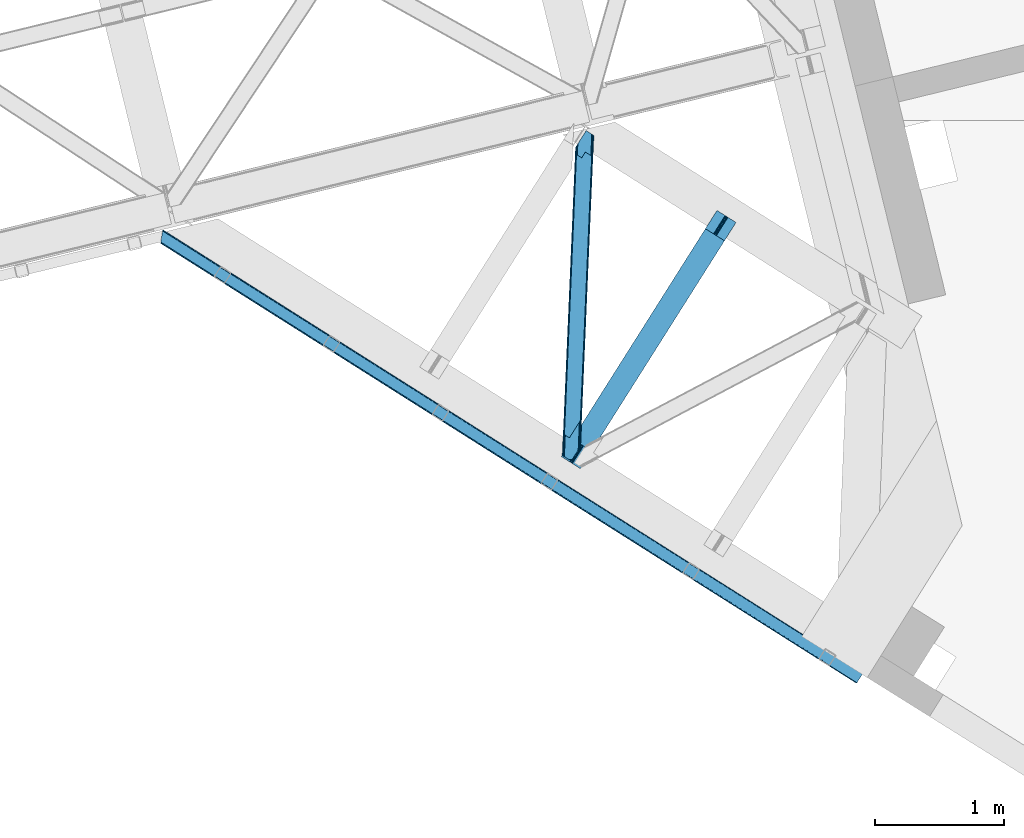
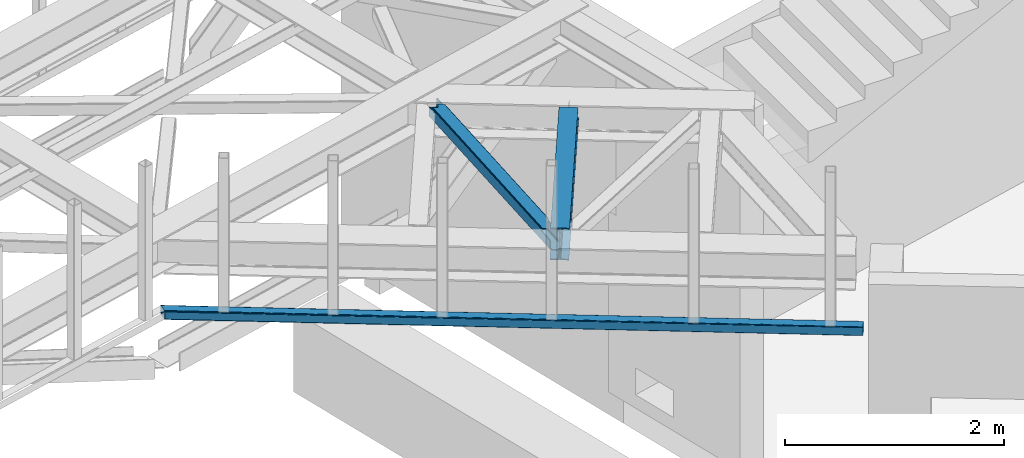
# One storey, part 49 of 67: 2 beams, 1 member.
"""IFC4 building model written with IfcOpenShell, lengths in millimetres."""

from ifc_helpers import new_model, entity, si_unit, converted_unit, derived_unit, direction, frame, origin, place, context, subcontext, project, spatial, triangles, polygons, material, type_object, element, save


model = new_model("IFC4")

# Units and contexts
model_context = context("Model", 3, precision=0.01, world=origin(), true_north=direction((6.12303176911189e-17, 1.0)))
plan_context = context("Plan", 3, precision=0.01, world=origin(), true_north=direction((6.12303176911189e-17, 1.0)))
body_context = subcontext(model_context, "Body", "Model", "MODEL_VIEW")
ifc_project = project(units=[si_unit("LENGTHUNIT", "METRE", prefix="MILLI"), si_unit("AREAUNIT", "SQUARE_METRE"), si_unit("VOLUMEUNIT", "CUBIC_METRE"), converted_unit("PLANEANGLEUNIT", "DEGREE", entity("IfcRatioMeasure", 0.0174532925199433), si_unit("PLANEANGLEUNIT", "RADIAN"), dimensions=[0, 0, 0, 0, 0, 0, 0]), si_unit("MASSUNIT", "GRAM", prefix="KILO"), derived_unit("MASSDENSITYUNIT", [(si_unit("MASSUNIT", "GRAM", prefix="KILO"), 1), (si_unit("LENGTHUNIT", "METRE"), -3)]), derived_unit("MOMENTOFINERTIAUNIT", [(si_unit("LENGTHUNIT", "METRE"), 4)]), si_unit("TIMEUNIT", "SECOND"), si_unit("FREQUENCYUNIT", "HERTZ"), si_unit("THERMODYNAMICTEMPERATUREUNIT", "DEGREE_CELSIUS"), derived_unit("THERMALTRANSMITTANCEUNIT", [(si_unit("MASSUNIT", "GRAM", prefix="KILO"), 1), (si_unit("THERMODYNAMICTEMPERATUREUNIT", "KELVIN"), -1), (si_unit("TIMEUNIT", "SECOND"), -3)]), derived_unit("VOLUMETRICFLOWRATEUNIT", [(si_unit("LENGTHUNIT", "METRE"), 3), (si_unit("TIMEUNIT", "SECOND"), -1)]), derived_unit("MASSFLOWRATEUNIT", [(si_unit("MASSUNIT", "GRAM", prefix="KILO"), 1), (si_unit("TIMEUNIT", "SECOND"), -1)]), derived_unit("ROTATIONALFREQUENCYUNIT", [(si_unit("TIMEUNIT", "SECOND"), -1)]), si_unit("ELECTRICCURRENTUNIT", "AMPERE"), si_unit("ELECTRICVOLTAGEUNIT", "VOLT"), si_unit("POWERUNIT", "WATT"), si_unit("FORCEUNIT", "NEWTON", prefix="KILO"), si_unit("ILLUMINANCEUNIT", "LUX"), si_unit("LUMINOUSFLUXUNIT", "LUMEN"), si_unit("LUMINOUSINTENSITYUNIT", "CANDELA"), derived_unit("USERDEFINED", [(si_unit("MASSUNIT", "GRAM", prefix="KILO"), -1), (si_unit("LENGTHUNIT", "METRE"), -2), (si_unit("TIMEUNIT", "SECOND"), 3), (si_unit("LUMINOUSFLUXUNIT", "LUMEN"), 1)]), derived_unit("LINEARVELOCITYUNIT", [(si_unit("LENGTHUNIT", "METRE"), 1), (si_unit("TIMEUNIT", "SECOND"), -1)]), si_unit("PRESSUREUNIT", "PASCAL"), derived_unit("USERDEFINED", [(si_unit("LENGTHUNIT", "METRE"), -2), (si_unit("MASSUNIT", "GRAM", prefix="KILO"), 1), (si_unit("TIMEUNIT", "SECOND"), -2)]), derived_unit("LINEARFORCEUNIT", [(si_unit("MASSUNIT", "GRAM", prefix="KILO"), 1), (si_unit("LENGTHUNIT", "METRE"), 1), (si_unit("TIMEUNIT", "SECOND"), -2), (si_unit("LENGTHUNIT", "METRE"), -1)]), derived_unit("PLANARFORCEUNIT", [(si_unit("MASSUNIT", "GRAM", prefix="KILO"), 1), (si_unit("LENGTHUNIT", "METRE"), 1), (si_unit("TIMEUNIT", "SECOND"), -2), (si_unit("LENGTHUNIT", "METRE"), -2)])], contexts=[model_context, plan_context])

# Site, building, storey
site_placement = place(None, origin())
site = spatial("IfcSite", under=ifc_project, at=site_placement, CompositionType="ELEMENT")
building_placement = place(site_placement, origin())
building = spatial("IfcBuilding", under=site, at=building_placement, CompositionType="ELEMENT")
storey_placement = place(building_placement, frame((0.0, 0.0, 19800.0)))
storey = spatial("IfcBuildingStorey", under=building, at=storey_placement, CompositionType="ELEMENT", Elevation=19800.0)

# Beam
ifc_material = material(Name="Metal painted (White)")
beam_type_1 = type_object("IfcBeamType", PredefinedType="BEAM")
beam_1_placement = place(storey_placement, frame((-2373.14584361384, 14260.2889328785, 3864.0)))
element("IfcBeam", 1, at=beam_1_placement, inside=storey, type_object=beam_type_1, material=ifc_material, ObjectType="Steel Beam", PredefinedType="BEAM", context=body_context, shape_type="Tessellation", body=[
    polygons([(147.919660694801, 2.16573425859679e-12, 11.0000000000018), (147.919660694804, 4.33146851719357e-12, 0.0), (1355.44607863557, 1910.06544717356, 0.0), (1355.44607863557, 1910.06544717355, 11.0000000000018), (90.4423068248274, 36.3366728266057, 11.0000000000018), (1297.96872476558, 1946.40212000016, 11.0000000000018), (85.2668642219479, 39.6085416920184, 12.2179274798152), (1292.7932821627, 1949.67398886557, 12.2179274798152), (80.8793358398553, 42.3822981822298, 15.6862915010257), (1288.40575378062, 1952.44774535578, 15.6862915010213), (77.9476831016699, 44.2356630157985, 20.8770650821548), (1285.47410104242, 1954.30111018934, 20.8770650821548), (76.9182235613008, 44.8864781975669, 26.9999999999939), (1284.44464150205, 1954.95192537111, 26.9999999999939), (1278.52785507426, 1958.69246522089, 26.9999999999939), (1278.52785507432, 1958.69246522022, 203.000000000006), (1284.44464150196, 1954.95192537085, 203.000000000006), (1207.52641794078, 2003.57894341848, 0.0), (1207.52641794077, 2003.57894341847, 10.9999999999975), (1265.00377181074, 1967.24227059188, 11.0000000000018), (1270.17921441362, 1963.97040172646, 12.2179274798152), (1274.56674279571, 1961.19664523624, 15.6862915010127), (1277.49839553388, 1959.34328040268, 20.8770650821592), (76.9182235613823, 44.8864781975192, 203.000000000006), (71.0014371335516, 48.6270180473361, 203.000000000006), (71.0014371335056, 48.6270180473665, 26.9999999999939), (69.9719775931373, 49.2778332291413, 20.8770650821592), (67.0403248549565, 51.1311980626949, 15.6862915010127), (62.6527964728685, 53.9049545529128, 12.2179274798152), (57.4773538699869, 57.176823418332, 11.0000000000018), (8.12150346973795e-12, 93.5134962449225, 10.9999999999975), (5.41433564649196e-12, 93.5134962449269, 0.0), (162.887980343835, 180.873386503032, 203.069792575793), (1195.07248712349, 1813.58297531797, 203.006342981529), (1194.53809439775, 1812.73773730252, 216.999999999998), (163.217821525431, 181.395193639939, 216.999999999998), (163.217821525544, 181.395193639874, 204.00000000001), (156.766642341062, 184.290495421957, 203.006342980143), (157.301035097542, 185.135733489758, 216.999999999998), (1188.62130797009, 1816.4782771522, 216.999999999998), (1188.6213079702, 1816.47827715213, 204.000000000006), (1188.95114918025, 1817.00008434255, 203.069791966819), (157.301035097816, 185.135733489578, 204.00000000001), (164.247281065643, 180.744378458268, 223.122934917842), (167.178933803824, 178.891013624725, 228.313708498975), (171.566462185928, 176.117257134518, 231.782072520173), (176.741904788822, 172.845388269138, 232.999999999995), (234.219258658959, 136.508715442803, 232.999999999999), (234.219258658962, 136.508715442803, 243.999999999997), (86.2995979637529, 230.022211687052, 244.000000000001), (86.2995979637521, 230.022211687052, 232.999999999999), (143.776951833897, 193.685538860712, 232.999999999999), (148.952394436778, 190.413669995315, 231.782072520181), (153.339922818875, 187.639913505108, 228.313708498984), (156.271575557062, 185.786548671563, 223.122934917842), (1187.59184842946, 1817.12909233409, 223.122934917842), (1184.66019569129, 1818.98245716763, 228.313708498979), (1180.27266730917, 1821.75621365784, 231.782072520181), (1175.0972247063, 1825.02808252324, 232.999999999999), (1117.61987083616, 1861.36475534957, 232.999999999999), (1117.61987083616, 1861.36475534957, 244.000000000001), (1265.53953153138, 1767.85125910532, 243.999999999997), (1265.53953153137, 1767.85125910532, 232.999999999999), (1208.06217766123, 1804.18793193166, 232.999999999995), (1202.88673505832, 1807.45980079704, 231.782072520173), (1198.49920667623, 1810.23355728725, 228.313708498975), (1195.56755393804, 1812.08692212079, 223.122934917842), (1194.53809439802, 1812.73773730233, 204.000000000006)], [[[1, 2, 3, 4]], [[5, 1, 4, 6]], [[7, 5, 6, 8]], [[9, 7, 8, 10]], [[11, 9, 10, 12]], [[13, 11, 12, 14]], [[15, 16, 17, 14, 12, 10, 8, 6, 4, 3, 18, 19, 20, 21, 22, 23]], [[13, 24, 25, 26, 27, 28, 29, 30, 31, 32, 2, 1, 5, 7, 9, 11]], [[2, 32, 18, 3]], [[32, 31, 19, 18]], [[31, 30, 20, 19]], [[27, 26, 15, 23]], [[28, 27, 23, 22]], [[29, 28, 22, 21]], [[30, 29, 21, 20]], [[33, 24, 13, 14, 17, 34, 35, 36, 37]], [[25, 38, 39, 40, 41, 42, 16, 15, 26]], [[38, 25, 24, 33]], [[42, 34, 17, 16]], [[39, 43, 37, 36, 44, 45, 46, 47, 48, 49, 50, 51, 52, 53, 54, 55]], [[40, 56, 57, 58, 59, 60, 61, 62, 63, 64, 65, 66, 67, 35, 68, 41]], [[44, 36, 35, 67]], [[45, 44, 67, 66]], [[46, 45, 66, 65]], [[47, 46, 65, 64]], [[48, 47, 64, 63]], [[49, 48, 63, 62]], [[50, 49, 62, 61]], [[51, 50, 61, 60]], [[52, 51, 60, 59]], [[53, 52, 59, 58]], [[54, 53, 58, 57]], [[55, 54, 57, 56]], [[39, 55, 56, 40]]], closed=False),
])

# Member
member_type = type_object("IfcMemberType", PredefinedType="BRACE")
member_placement = place(storey_placement, frame((-2366.79041748047, 14329.5497589111, 3964.00063476562)))
element("IfcMember", 2, at=member_placement, inside=storey, type_object=member_type, ObjectType="Steel Horizontal Brace", PredefinedType="BRACE", context=body_context, shape_type="Tessellation", body=[
    triangles([(100.655629348755, 2374.38995361328, 113.0000793457), (107.475271224976, 2370.07742614746, 113.0000793457), (102.696783828736, 2421.82891845703, 113.0000793457), (109.879194259644, 2433.19217834473, 113.0000793457), (110.120894622803, 2433.18287658691, 113.0000793457), (107.407542800903, 2370.08091430664, 113.0000793457), (110.142259597778, 2433.72354125977, 112.135015869138), (107.407397460938, 2370.08091430664, 115.49992675781), (13.930835723877, 195.896182250977, 115.49992675781), (110.180774688721, 2433.72237854004, 24.4985046386719), (13.8035179138183, 192.844042968751, 111.22111816406), (6.85336074829092, 30.4120971679695, 24.4985046386719), (13.6123958587646, 188.365246582032, 109.609588623047), (13.4169136047362, 183.884124755859, 108.000384521481), (6.81949653625497, 30.4144226074222, 108.000384521481), (0.0, 34.7257873535164, 108.000384521481), (6.82414741516141, 30.4144226074222, 108.000384521481), (13.4262153625491, 183.885287475587, 108.000384521481), (6.6020679473877, 188.196652221681, 108.000384521481), (6.98896293640155, 197.155407714845, 111.22111816406), (13.808604812622, 192.842880249023, 111.22111816406), (13.9405735015871, 195.89501953125, 115.49992675781), (14.3164226531985, 196.336853027344, 118.999713134763), (7.14723815917978, 200.865646362305, 118.999713134763), (7.06817321777362, 199.011108398438, 115.109252929688), (13.6174827575683, 188.364083862305, 109.609588623047), (6.79784088134784, 192.676611328125, 109.609588623047), (15.8281036376952, 195.378771972657, 121.887908935547), (108.771703720093, 2369.25654602051, 122.19719238281), (112.471768569947, 2366.92064208984, 127.873590087889), (107.475271224976, 2370.07742614746, 115.49992675781), (18.9633773803712, 193.396334838868, 127.873590087889), (118.001518249512, 2363.42318115235, 131.666381835938), (24.4974872589114, 189.900036621095, 131.666381835938), (124.526556015015, 2359.29668884277, 132.998858642575), (31.0226703643798, 185.773544311523, 132.998858642575), (129.009131240845, 2463.45079650879, 6.99957275390625), (121.8158203125, 2452.07358398438, 8.33204956054396), (23.8754322052005, 19.6336853027351, 6.99957275390625), (17.3502490997316, 23.7590148925792, 8.33204956054396), (115.717791366577, 2442.42882385254, 12.1248413085923), (11.8161392211914, 27.2564758300778, 12.1248413085923), (111.644784164429, 2435.9838684082, 17.8035644531228), (8.12043457031268, 29.5935424804684, 17.8035644531228), (110.214638900757, 2433.72121582031, 24.4985046386719), (6.82414741516141, 30.4144226074222, 24.4985046386719), (102.696783828736, 2421.82891845703, 17.4989318847656), (100.655629348755, 2374.38995361328, 122.499499511716), (7.14723815917978, 200.865646362305, 122.499499511716), (0.0, 34.7257873535164, 17.4989318847656), (117.706914138794, 2363.6092163086, 139.998431396481), (111.181876373291, 2367.73570861817, 138.668280029295), (17.6778453826905, 194.212564086914, 138.668280029295), (24.2030284881594, 190.086071777345, 139.998431396481), (105.647621154785, 2371.23200683594, 134.873162841795), (12.1437355041503, 197.708862304688, 134.873162841795), (101.952061843872, 2373.56907348633, 129.196765136716), (8.44817619323749, 200.045928955078, 129.196765136716), (151.68507270813, 2342.12680664063, 132.998858642575), (151.68507270813, 2342.12680664063, 139.998431396481), (56.1432300567626, 169.89428100586, 132.998858642575), (56.1432300567626, 169.89428100586, 139.998431396481), (104.126929092407, 2424.09273376465, 10.8016662597656), (1.30093803405771, 33.9060699462898, 10.8016662597656), (108.200081634522, 2430.53652648926, 5.12526855468604), (4.99649734497098, 31.5690032958992, 5.12526855468604), (114.298110580444, 2440.18244934082, 1.33247680663771), (10.5307525634767, 28.0715423583988, 1.33247680663771), (121.491276168823, 2451.55966186523, 0.0), (17.0557903289796, 23.9462127685547, 0.0), (186.00768699646, 2553.61506042481, 6.99957275390625), (186.00768699646, 2553.61506042481, 0.0), (110.214638900757, 2433.72121582031, 112.135015869138), (53.3593883514404, 0.995288085938228, 6.99957275390625), (53.3593883514404, 0.995288085938228, 0.0), (76.5082660675048, 0.0, 0.0), (76.5082660675048, 0.0, 6.99957275390625), (124.379326629639, 75.7232849121101, 0.0), (229.786700820923, 2525.94000549316, 0.0), (116.861471557617, 63.8309875488285, 6.99957275390625), (222.967058944702, 2530.25253295898, 6.99957275390625), (236.311738586426, 2521.8135131836, 1.33247680663771), (131.572637557983, 87.1004974365242, 1.33247680663771), (241.845993804932, 2518.31721496582, 5.12526855468604), (137.670666503906, 96.7452575683601, 5.12526855468604), (245.541553115845, 2515.98014831543, 10.8016662597656), (141.743673706055, 103.190213012696, 10.8016662597656), (246.837985610962, 2515.15926818848, 17.4989318847656), (143.173964309693, 105.452865600586, 17.4989318847656), (240.018343734741, 2519.4717956543, 24.4985046386719), (238.721911239624, 2520.29267578125, 17.8035644531228), (135.656109237671, 93.5605682373043, 24.4985046386719), (134.225963973999, 91.2979156494148, 17.8035644531228), (235.026351928711, 2522.62974243164, 12.1248413085923), (130.152811431885, 84.8529602050785, 12.1248413085923), (229.492096710205, 2526.12604064941, 8.33204956054396), (124.054782485962, 75.2082000732426, 8.33204956054396), (143.173964309693, 105.452865600586, 108.000384521481), (135.656109237671, 93.5605682373043, 108.000384521481), (246.837985610962, 2515.15926818848, 108.000384521481), (240.018343734741, 2519.4717956543, 108.000384521481), (144.900748443604, 308.420709228516, 108.000384521481), (152.418603515625, 320.313006591798, 108.000384521481), (233.416130447388, 2366.00093078613, 108.000384521481), (240.235772323609, 2361.68840332031, 108.000384521481), (233.02938079834, 2357.04217529297, 111.22111816406), (233.225008392334, 2361.52213439942, 109.609588623047), (232.901917648316, 2353.99003601074, 115.49992675781), (144.985917663574, 310.428726196289, 109.000323486325), (144.943333053589, 309.42413635254, 108.500354003903), (144.985917663574, 310.428726196289, 115.49992675781), (143.555627059937, 308.164910888672, 122.19719238281), (152.50362739563, 322.321023559571, 122.499499511716), (151.073482131958, 320.057208251954, 129.196765136716), (147.00047492981, 313.613415527345, 134.873162841795), (139.482619857788, 301.721118164063, 127.873590087889), (152.50362739563, 322.321023559571, 109.000323486325), (140.902445983887, 303.967492675782, 138.668280029295), (133.384590911865, 292.076358032227, 131.666381835938), (133.709135055542, 292.590280151368, 139.998431396481), (126.19127998352, 280.697982788086, 132.998858642575), (239.853528213501, 2352.73081054688, 111.22111816406), (239.774317932129, 2350.87510986328, 115.109252929688), (240.044650268555, 2357.20960693359, 109.609588623047), (239.690747451783, 2349.01940917969, 118.999713134763), (239.690747451783, 2349.01940917969, 122.499499511716), (152.461188125611, 321.316433715821, 108.500354003903), (222.639462661743, 2359.80014648438, 139.998431396481), (179.929569625855, 2386.80082397461, 139.998431396481), (215.819820785523, 2364.1126739502, 132.998858642575), (179.929569625855, 2386.80082397461, 132.998858642575), (234.698755645752, 2352.17735595703, 134.873162841795), (227.879113769531, 2356.48988342285, 127.873590087889), (229.164500427246, 2355.67365417481, 138.668280029295), (231.014387512207, 2354.50628356934, 121.887908935547), (238.394314956665, 2349.84028930664, 129.196765136716), (232.526068496704, 2353.54936523438, 118.999713134763), (222.344858551025, 2359.98618164063, 131.666381835938)], [[1, 2, 3], [4, 3, 2], [5, 6, 7], [6, 8, 9], [6, 10, 7], [6, 11, 10], [9, 11, 6], [12, 10, 11], [13, 12, 11], [12, 13, 14], [15, 12, 14], [16, 17, 18], [18, 19, 16], [20, 21, 22], [23, 24, 25], [25, 22, 23], [22, 25, 20], [26, 21, 27], [20, 27, 21], [18, 26, 19], [27, 19, 26], [28, 29, 30], [29, 28, 23], [23, 31, 29], [23, 22, 31], [30, 32, 28], [30, 33, 32], [34, 32, 33], [33, 35, 34], [36, 34, 35], [37, 38, 39], [40, 39, 38], [38, 41, 40], [42, 40, 41], [41, 43, 42], [44, 42, 43], [43, 45, 44], [46, 44, 45], [1, 25, 24], [47, 20, 1], [1, 3, 47], [24, 48, 1], [49, 48, 24], [20, 47, 50], [50, 19, 27], [50, 16, 19], [27, 20, 50], [20, 25, 1], [51, 52, 53], [53, 54, 51], [52, 55, 56], [56, 53, 52], [55, 57, 58], [58, 56, 55], [57, 48, 49], [49, 58, 57], [30, 52, 55], [59, 60, 35], [60, 51, 35], [52, 33, 51], [30, 33, 52], [33, 35, 51], [48, 31, 29], [57, 30, 55], [30, 57, 29], [57, 48, 29], [1, 31, 48], [1, 2, 31], [32, 53, 56], [61, 62, 36], [62, 54, 36], [53, 34, 54], [32, 34, 53], [34, 36, 54], [58, 28, 32], [56, 58, 32], [28, 58, 49], [49, 23, 28], [49, 24, 23], [47, 63, 64], [64, 50, 47], [63, 65, 66], [66, 64, 63], [65, 67, 68], [68, 66, 65], [67, 69, 70], [70, 68, 67], [41, 65, 67], [41, 67, 38], [37, 38, 69], [43, 65, 41], [71, 37, 72], [69, 72, 37], [38, 67, 69], [63, 65, 43], [3, 47, 45], [45, 73, 3], [4, 3, 73], [63, 43, 47], [43, 45, 47], [68, 42, 66], [40, 70, 39], [74, 39, 75], [40, 42, 68], [39, 70, 75], [40, 68, 70], [64, 66, 42], [16, 50, 46], [44, 46, 50], [17, 16, 46], [42, 44, 64], [44, 50, 64], [76, 77, 75], [74, 75, 77], [70, 78, 75], [78, 70, 69], [76, 75, 78], [69, 79, 78], [79, 69, 72], [74, 77, 80], [39, 80, 37], [80, 39, 74], [81, 37, 80], [81, 71, 37], [79, 82, 83], [83, 78, 79], [82, 84, 85], [85, 83, 82], [84, 86, 87], [87, 85, 84], [86, 88, 89], [89, 87, 86], [90, 91, 92], [93, 92, 91], [91, 94, 93], [95, 93, 94], [94, 96, 95], [97, 95, 96], [96, 81, 97], [80, 97, 81], [85, 93, 95], [92, 89, 98], [98, 99, 92], [92, 93, 89], [93, 87, 89], [93, 85, 87], [83, 85, 95], [80, 78, 97], [95, 97, 83], [80, 77, 76], [97, 78, 83], [80, 76, 78], [91, 90, 88], [88, 86, 91], [94, 86, 84], [86, 94, 91], [90, 100, 88], [90, 101, 100], [94, 84, 82], [96, 82, 79], [72, 81, 79], [71, 81, 72], [81, 96, 79], [96, 94, 82], [99, 98, 102], [103, 102, 98], [104, 105, 100], [100, 101, 104], [106, 90, 102], [104, 90, 107], [104, 101, 90], [108, 106, 109], [106, 107, 90], [110, 109, 106], [92, 102, 90], [92, 99, 102], [102, 110, 106], [109, 111, 108], [112, 111, 113], [113, 114, 112], [115, 112, 114], [112, 115, 116], [111, 117, 113], [111, 109, 117], [116, 115, 118], [119, 118, 120], [62, 121, 120], [61, 121, 62], [121, 119, 120], [119, 116, 118], [88, 122, 117], [123, 117, 122], [124, 122, 88], [88, 105, 124], [105, 88, 100], [103, 89, 88], [113, 125, 126], [88, 117, 127], [123, 125, 117], [117, 125, 113], [88, 127, 103], [89, 103, 98], [120, 51, 60], [51, 120, 54], [62, 54, 120], [60, 128, 120], [128, 60, 129], [121, 35, 59], [35, 121, 36], [61, 36, 121], [59, 130, 121], [130, 59, 131], [132, 133, 134], [135, 136, 126], [126, 125, 137], [137, 135, 126], [133, 136, 135], [132, 136, 133], [138, 128, 134], [134, 133, 138], [138, 130, 128], [130, 129, 128], [131, 129, 130], [133, 135, 112], [135, 137, 111], [111, 112, 135], [137, 108, 111], [112, 116, 133], [138, 133, 116], [116, 119, 138], [130, 138, 119], [119, 121, 130], [137, 125, 123], [122, 106, 108], [124, 105, 107], [104, 107, 105], [122, 124, 106], [107, 106, 124], [108, 123, 122], [123, 108, 137], [126, 136, 113], [114, 113, 136], [136, 132, 114], [115, 114, 132], [132, 134, 115], [118, 115, 134], [134, 128, 118], [120, 118, 128], [129, 131, 60], [59, 60, 131]]),
])

# Beam
beam_type_2 = type_object("IfcBeamType", PredefinedType="BEAM")
beam_2_placement = place(storey_placement, frame((-5482.19502410889, 12594.2963745117, 3278.00064697265)))
element("IfcBeam", 3, at=beam_2_placement, inside=storey, type_object=beam_type_2, ObjectType="Steel Beam", PredefinedType="BEAM", context=body_context, shape_type="Tessellation", body=[
    triangles([(15.8013610839844, 3509.74390869141, 99.9985473632805), (1.75279998779297, 3423.97705078125, 99.9985473632805), (5447.18182697296, 76.072100830077, 99.9985473632805), (5404.4346269846, 8.45180969238208, 99.9985473632805), (1.13539581298846, 3420.18774719238, 98.5358459472664), (5402.38918497562, 5.21712341308557, 99.2381286621094), (0.512759399413881, 3416.39728088379, 97.0708190917976), (5400.6545797348, 2.47543029785083, 97.0708190917976), (0.254635620117369, 3414.8264465332, 93.5361511230476), (5399.49745559692, 0.642984008789426, 93.8268310546882), (0.0, 3413.25677490234, 89.999157714843), (5399.08948631287, 0.0, 89.999157714843), (5399.08948631287, 0.0, 9.9993896484375), (0.0, 3413.25677490234, 9.9993896484375), (5399.49745559692, 0.642984008789426, 6.17171630859229), (5400.6545797348, 2.47543029785083, 2.92772827148292), (0.254635620117369, 3414.8264465332, 6.4647216796875), (5402.38918497562, 5.21712341308557, 0.760418701171147), (0.512759399413881, 3416.39728088379, 2.92772827148292), (5404.4346269846, 8.45180969238208, 0.0), (1.13539581298846, 3420.18774719238, 1.46502685546875), (1.75279998779297, 3423.97705078125, 0.0), (15.8013610839844, 3509.74390869141, 0.0), (5447.18182697296, 76.072100830077, 0.0), (5449.22727352381, 79.3067871093754, 0.760418701171147), (5450.96187422276, 82.0496429443356, 2.92772827148292), (16.4234161376953, 3513.53553771973, 1.46502685546875), (5452.11893250346, 83.8820892333988, 6.17171630859229), (17.0414016723635, 3517.32484130859, 2.92772827148292), (5452.52690405846, 84.5250732421864, 9.9993896484375), (17.3001068115236, 3518.89451293945, 6.4647216796875), (17.5588119506838, 3520.46534729004, 9.9993896484375), (5452.52690405846, 84.5250732421864, 89.999157714843), (17.5588119506838, 3520.46534729004, 89.999157714843), (17.3001068115236, 3518.89451293945, 93.5361511230476), (5452.11893250346, 83.8820892333988, 93.8268310546882), (17.0414016723635, 3517.32484130859, 97.0708190917976), (5450.96187422276, 82.0496429443356, 97.0708190917976), (16.4234161376953, 3513.53553771973, 98.5358459472664), (5449.22727352381, 79.3067871093754, 99.2381286621094), (5448.29159526229, 77.8231567382809, 92.0711242675789), (5449.448653543, 79.6556030273441, 88.8271362304695), (5449.85662509799, 80.299749755859, 84.9994628906243), (5444.5115480125, 71.8467773437496, 94.9988525390618), (5446.5569241643, 75.0814636230461, 94.2384338378906), (5448.29159526229, 77.8231567382809, 7.92742309570167), (5449.85662509799, 80.299749755859, 14.9990844726563), (5449.448653543, 79.6556030273441, 11.1737365722656), (5444.5115480125, 71.8467773437496, 4.99969482421875), (5446.5569241643, 75.0814636230461, 5.7601135253899), (5403.32938013077, 6.70191650390552, 92.0711242675789), (5407.104908216, 12.6782958984368, 94.9988525390618), (5405.05946166515, 9.44360961914026, 94.2384338378906), (5401.76427762508, 4.22648620605469, 84.9994628906243), (5402.16773228645, 4.86947021484411, 88.8271362304695), (5403.32938013077, 6.70191650390552, 7.92742309570167), (5407.104908216, 12.6782958984368, 4.99969482421875), (5405.05946166515, 9.44360961914026, 5.7601135253899), (5401.76427762508, 4.22648620605469, 14.9990844726563), (5402.16773228645, 4.86947021484411, 11.1737365722656), (16.4234161376953, 3513.53553771973, 11.4644165039063), (16.677470397949, 3515.10404663086, 14.9990844726563), (16.1647109985352, 3511.96470336914, 7.92742309570167), (14.9252517700197, 3504.38377075195, 4.99969482421875), (15.5426559448242, 3508.17423706055, 6.4647216796875), (16.1647109985352, 3511.96470336914, 92.0711242675789), (16.677470397949, 3515.10404663086, 84.9994628906243), (16.4234161376953, 3513.53553771973, 88.5341308593743), (15.5426559448242, 3508.17423706055, 93.5361511230476), (14.9252517700197, 3504.38377075195, 94.9988525390618), (1.38945007324219, 3421.75741882324, 7.92742309570167), (1.13539581298846, 3420.18774719238, 11.4644165039063), (2.63356018066406, 3429.33835144043, 4.99969482421875), (2.01150512695313, 3425.54788513184, 6.4647216796875), (0.876690673828307, 3418.6169128418, 14.9990844726563), (2.01150512695313, 3425.54788513184, 93.5361511230476), (1.38945007324219, 3421.75741882324, 92.0711242675789), (1.13539581298846, 3420.18774719238, 88.5341308593743), (2.63356018066406, 3429.33835144043, 94.9988525390618), (0.876690673828307, 3418.6169128418, 84.9994628906243)], [[1, 2, 3], [4, 3, 2], [4, 2, 5], [6, 5, 7], [8, 7, 9], [10, 9, 11], [11, 12, 10], [9, 10, 8], [7, 8, 6], [5, 6, 4], [13, 12, 11], [11, 14, 13], [15, 13, 14], [16, 15, 17], [18, 16, 19], [20, 18, 21], [21, 22, 20], [19, 21, 18], [17, 19, 16], [14, 17, 15], [22, 23, 24], [24, 20, 22], [25, 24, 23], [26, 25, 27], [28, 26, 29], [30, 28, 31], [31, 32, 30], [29, 31, 28], [27, 29, 26], [23, 27, 25], [33, 30, 34], [32, 34, 30], [33, 34, 35], [36, 35, 37], [38, 37, 39], [40, 39, 1], [1, 3, 40], [39, 40, 38], [37, 38, 36], [35, 36, 33], [36, 41, 42], [43, 30, 33], [36, 42, 33], [36, 38, 41], [42, 43, 33], [41, 38, 40], [44, 3, 4], [3, 45, 40], [45, 3, 44], [45, 41, 40], [28, 46, 26], [47, 30, 43], [30, 48, 28], [48, 30, 47], [28, 48, 46], [24, 49, 20], [25, 26, 46], [46, 50, 25], [50, 49, 24], [24, 25, 50], [51, 6, 8], [4, 52, 44], [4, 53, 52], [53, 4, 6], [51, 53, 6], [54, 12, 13], [10, 55, 51], [8, 10, 51], [55, 10, 12], [54, 55, 12], [18, 56, 16], [20, 49, 57], [57, 58, 20], [58, 56, 18], [18, 20, 58], [15, 16, 56], [13, 59, 54], [60, 13, 15], [13, 60, 59], [60, 15, 56], [61, 62, 32], [63, 31, 29], [63, 29, 27], [32, 62, 34], [32, 31, 61], [63, 61, 31], [64, 23, 22], [27, 23, 65], [64, 65, 23], [27, 65, 63], [66, 39, 37], [67, 34, 62], [68, 35, 34], [68, 34, 67], [37, 35, 66], [39, 69, 1], [35, 68, 66], [39, 66, 69], [1, 70, 2], [70, 1, 69], [71, 17, 72], [22, 73, 64], [22, 21, 74], [22, 74, 73], [74, 21, 71], [72, 14, 75], [17, 71, 19], [19, 71, 21], [75, 14, 11], [17, 14, 72], [5, 2, 76], [77, 5, 76], [78, 9, 77], [79, 2, 70], [2, 79, 76], [77, 7, 5], [11, 80, 75], [9, 78, 11], [80, 11, 78], [9, 7, 77], [79, 70, 44], [44, 52, 79], [55, 54, 80], [51, 55, 78], [53, 51, 77], [52, 53, 76], [76, 79, 52], [77, 76, 53], [78, 77, 51], [80, 78, 55], [54, 59, 80], [75, 80, 59], [57, 73, 74], [58, 74, 71], [56, 71, 72], [60, 72, 75], [75, 59, 60], [72, 60, 56], [71, 56, 58], [74, 58, 57], [64, 73, 49], [57, 49, 73], [47, 62, 61], [48, 61, 63], [46, 63, 65], [50, 65, 64], [64, 49, 50], [65, 50, 46], [63, 46, 48], [61, 48, 47], [47, 43, 67], [67, 62, 47], [45, 44, 70], [41, 45, 69], [42, 41, 66], [43, 42, 68], [68, 67, 43], [66, 68, 42], [69, 66, 41], [70, 69, 45]]),
])

save(model, "model.ifc")
